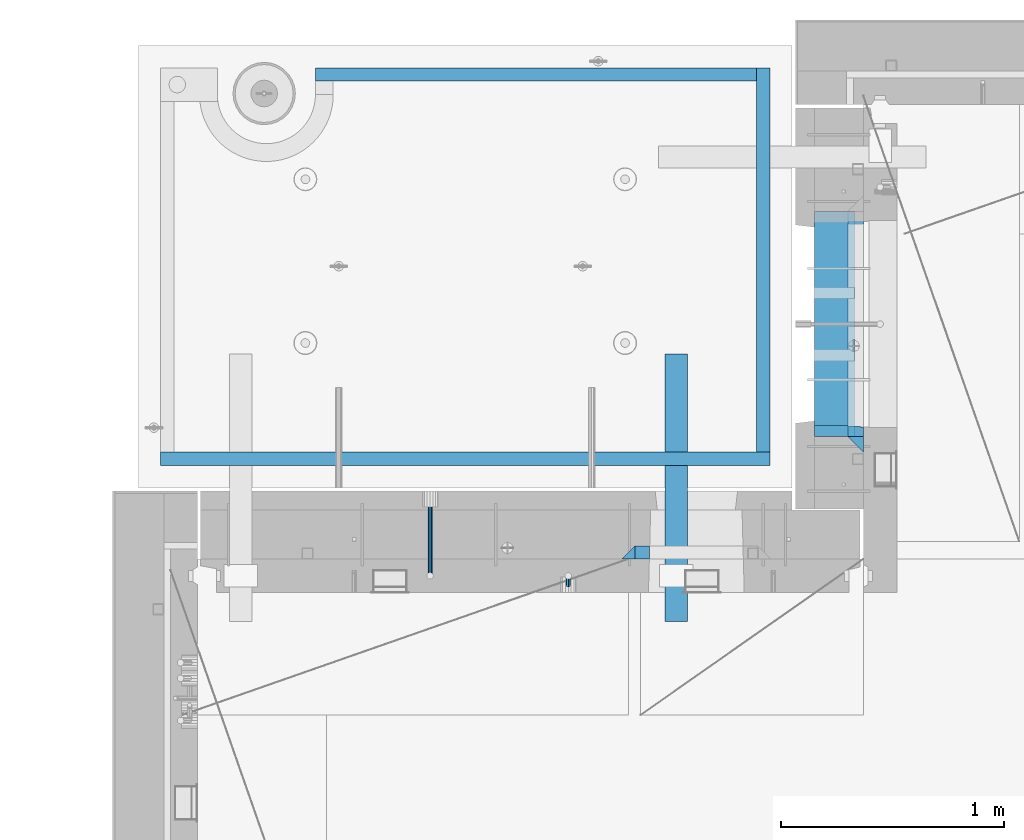
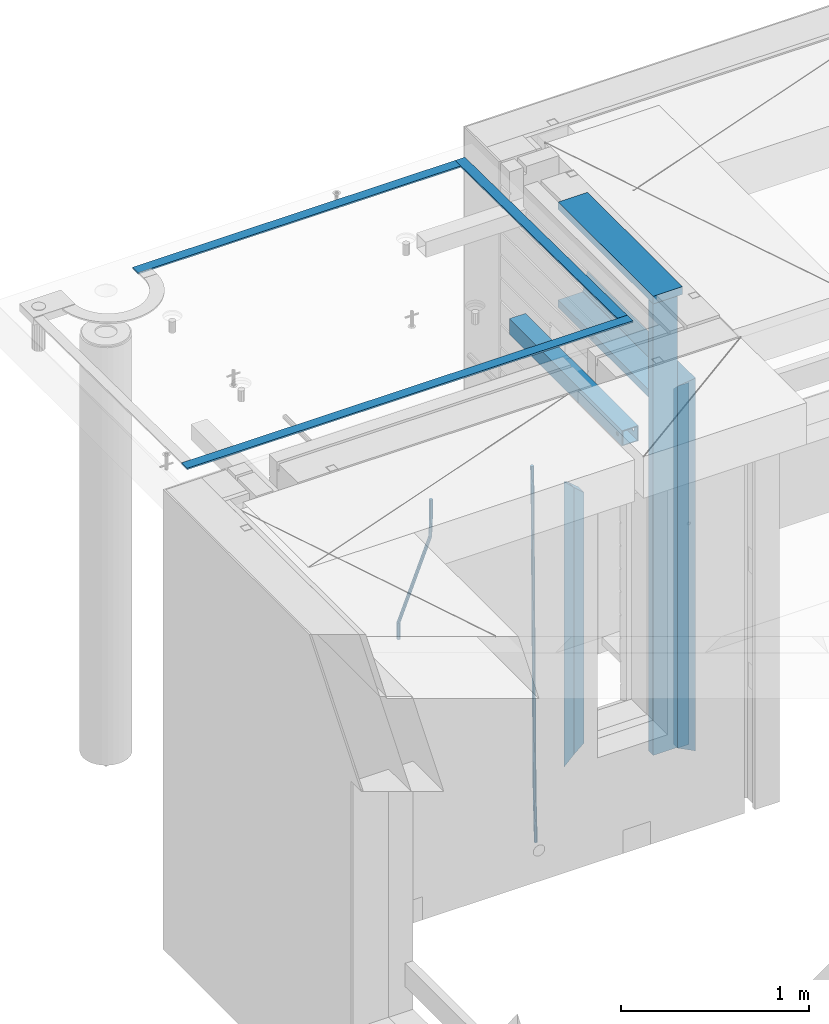
# One storey, part 116 of 349: 14 beams, 4 elements without a shape of their own.
"""IFC2X3 building model written with IfcOpenShell, lengths in millimetres."""

from ifc_helpers import new_model, si_unit, frame, origin_with_axes, place, context, subcontext, project, spatial, faceted_brep, material, type_object, element, aggregate, save


model = new_model("IFC2X3")

# Units and contexts
model_context = context("Model", 3, precision=1e-05, world=origin_with_axes())
body_context = subcontext(model_context, "Body", "Model", "MODEL_VIEW")
ifc_project = project(units=[si_unit("LENGTHUNIT", "METRE", prefix="MILLI"), si_unit("AREAUNIT", "SQUARE_METRE"), si_unit("VOLUMEUNIT", "CUBIC_METRE"), si_unit("MASSUNIT", "GRAM", prefix="KILO"), si_unit("TIMEUNIT", "SECOND"), si_unit("PLANEANGLEUNIT", "RADIAN"), si_unit("SOLIDANGLEUNIT", "STERADIAN"), si_unit("THERMODYNAMICTEMPERATUREUNIT", "DEGREE_CELSIUS"), si_unit("LUMINOUSINTENSITYUNIT", "LUMEN")], contexts=[model_context])

# Site, building, storey
site_placement = place(None, origin_with_axes())
site = spatial("IfcSite", under=ifc_project, at=site_placement, CompositionType="ELEMENT")
building_placement = place(site_placement, origin_with_axes())
building = spatial("IfcBuilding", under=site, at=building_placement, CompositionType="ELEMENT")
storey_placement = place(building_placement, origin_with_axes())
storey = spatial("IfcBuildingStorey", under=building, at=storey_placement, Name="4", CompositionType="ELEMENT", Elevation=0.0)

# Assembly, beams
assembly_1_placement = place(storey_placement, origin_with_axes())
assembly_1 = element("IfcElementAssembly", 1, at=assembly_1_placement, inside=storey, AssemblyPlace="NOTDEFINED", PredefinedType="REINFORCEMENT_UNIT")
ifc_material_1 = material(Name="CONCRETE/C25/30")
beam_type_1 = type_object("IfcBeamType", PredefinedType="NOTDEFINED")
beam_1_placement = place(assembly_1_placement, frame((10955.0, 22209.9998901814, 93140.0), z_axis=(0.0, 0.0, -1.0), x_axis=(0.0, -1.0, 0.0)))
beam_1 = element("IfcBeam", 2, at=beam_1_placement, type_object=beam_type_1, material=ifc_material_1, Name="SK", context=body_context, shape_type="Brep", body=[
    faceted_brep([(70.0000000000164, -35.0, 35.0), (70.0000000000164, 35.0, 35.0), (0.0, -35.0, -35.0), (1079.99961853027, -35.0, 35.0), (1079.99961853027, 35.0, 35.0), (1149.99961853027, -35.0, -35.0)], [[[0, 1, 2]], [[1, 0, 3, 4]], [[2, 1, 4, 5]], [[0, 2, 5, 3]], [[5, 4, 3]]]),
])
beam_2_placement = place(assembly_1_placement, frame((10955.0, 21095.0002716511, 93175.0), z_axis=(0.0, 1.0, 0.0), x_axis=(0.0, 0.0, -1.0)))
beam_2 = element("IfcBeam", 3, at=beam_2_placement, type_object=beam_type_1, material=ifc_material_1, Name="SK", context=body_context, shape_type="Brep", body=[
    faceted_brep([(2420.0, -35.0, 35.0), (2420.0, -35.0, -35.0), (2420.0, 35.0, 35.0), (70.0000000000164, -35.0, 35.0), (0.0, -35.0, -35.0), (70.0000000000164, 35.0, 35.0)], [[[0, 1, 2]], [[1, 0, 3, 4]], [[2, 1, 4, 5]], [[0, 2, 5, 3]], [[3, 5, 4]]]),
])
beam_type_2 = type_object("IfcBeamType", PredefinedType="NOTDEFINED")
beam_3_placement = place(assembly_1_placement, frame((10955.0, 21155.0002716511, 93105.0), z_axis=(0.0, 1.0, 0.0), x_axis=(0.0, 0.0, -1.0)))
beam_3 = element("IfcBeam", 4, at=beam_3_placement, type_object=beam_type_2, material=ifc_material_1, Name="SK", context=body_context, shape_type="Brep", body=[
    faceted_brep([(2350.0, -35.0, -25.0), (2350.0, 35.0, -25.0), (2350.0, 35.0, 20.6410256410309), (2350.0, -35.0, 18.8461538461561), (43.8461538461561, -35.0, 18.8461538461543), (0.0, -35.0, -25.0), (0.0, 35.0, -25.0), (45.6410256410309, 35.0, 20.6410256410254)], [[[0, 1, 2, 3]], [[0, 3, 4, 5]], [[1, 0, 5, 6]], [[2, 1, 6, 7]], [[3, 2, 7, 4]], [[7, 6, 5, 4]]]),
])
ifc_material_2 = material(Name="TIMBER")
beam_type_3 = type_object("IfcBeamType", Name="50X150", PredefinedType="NOTDEFINED")
beam_4_placement = place(assembly_1_placement, frame((10845.0, 22139.9998901814, 93080.0), z_axis=(0.0, 0.0, -1.0), x_axis=(0.0, -1.0, 0.0)))
beam_4 = element("IfcBeam", 5, at=beam_4_placement, type_object=beam_type_3, material=ifc_material_2, ObjectType="50X150", context=body_context, shape_type="Brep", body=[
    faceted_brep([(0.0, 75.0, -25.0), (1.81898940354586e-12, 75.0, 25.0), (1009.99961853027, 75.0, 25.0), (1009.99961853027, 75.0, -25.0), (1.81898940354586e-12, -75.0000000000009, 25.0), (1009.99961853027, -75.0, 25.0), (0.0, -75.0, -25.0), (1009.99961853027, -75.0, -25.0)], [[[0, 1, 2, 3]], [[1, 4, 5, 2]], [[4, 6, 7, 5]], [[6, 0, 3, 7]], [[5, 7, 3, 2]], [[6, 4, 1, 0]]]),
])
beam_5_placement = place(assembly_1_placement, frame((10845.0, 21155.0002716511, 93690.0), z_axis=(0.0, 1.0, 0.0), x_axis=(0.0, 0.0, -1.0)))
beam_5 = element("IfcBeam", 6, at=beam_5_placement, type_object=beam_type_3, material=ifc_material_2, ObjectType="50X150", context=body_context, shape_type="Brep", body=[
    faceted_brep([(0.0, 75.0, -25.0), (1.81898940354586e-12, 75.0, 25.0), (2930.0, 75.0, 25.0), (2930.0, 75.0, -25.0), (1.81898940354586e-12, -75.0000000000009, 25.0), (2930.0, -75.0, 25.0), (0.0, -75.0, -25.0), (2930.0, -75.0, -25.0)], [[[0, 1, 2, 3]], [[1, 4, 5, 2]], [[4, 6, 7, 5]], [[6, 0, 3, 7]], [[5, 7, 3, 2]], [[6, 4, 1, 0]]]),
])

assembly_2_placement = place(storey_placement, origin_with_axes())
assembly_2 = element("IfcElementAssembly", 7, at=assembly_2_placement, inside=storey, AssemblyPlace="NOTDEFINED", PredefinedType="REINFORCEMENT_UNIT")
ifc_material_3 = material()
beam_type_4 = type_object("IfcBeamType", Name="D20", PredefinedType="NOTDEFINED")
beam_6_placement = place(assembly_2_placement, frame((9665.0017200335, 20464.9951872276, 90990.0), z_axis=(-0.000205762999925498, 0.999642804629538, -0.0267249099901004), x_axis=(4.30000201928125e-08, 0.0267249099948059, 0.999642825806181)))
beam_6 = element("IfcBeam", 8, at=beam_6_placement, type_object=beam_type_4, material=ifc_material_3, Name="JM20", ObjectType="D20", context=body_context, shape_type="Brep", body=[
    faceted_brep([(0.0, -10.0, 0.0), (-4.19531716033816e-08, -7.07106781186667, -7.07106781187031), (60.4266690400545, -7.0710677960451, -7.07106780570757), (60.4266690441291, -9.99999998418934, 6.15546014159918e-09), (0.0, 0.0, -10.0), (60.426669036824, 1.58106558956206e-08, -9.99999999384454), (4.196772351861e-08, 7.07106781186303, -7.07106781186667), (60.4266690363438, 7.07106782768096, -7.07106780570757), (0.0, 10.0, 0.0), (60.4266690388904, 10.0000000158179, 6.15182216279209e-09), (4.196772351861e-08, 7.07106781185939, 7.07106781185939), (60.4266690429649, 7.07106782768096, 7.07106781802577), (0.0, 0.0, 10.0), (60.4266690461809, 1.58179318532348e-08, 10.0000000061555), (-4.19531716033816e-08, -7.07106781187031, 7.07106781185939), (60.4266690466611, -7.07106779605238, 7.07106781802213), (61.0378400410118, -7.07106779588503, -7.07106780564936), (60.991799419251, -9.99999998403655, 6.21366780251265e-09), (61.0569027789461, 1.5985278878361e-08, -9.99999999378269), (61.0378209396877, 7.07106782784831, -7.07106780564936), (60.9917724058905, 10.0000000159635, 6.21366780251265e-09), (60.9457317841297, 7.07106782781193, 7.0710678180767), (60.9266690461809, 1.59488990902901e-08, 10.0000000062028), (60.9457508854539, -7.07106779591413, 7.0710678180767), (61.6489592143771, -7.07106614513759, -7.06310863441468), (61.5568818710308, -9.9999984576425, 0.00735959856683621), (61.6870830769039, 1.71821739058942e-06, -9.99179257185824), (61.6489210170112, 7.07106947854481, -7.06310888312146), (61.556827851804, 10.0000015422847, 0.00735924683976918), (61.4647505084577, 7.07106922979438, 7.07782747982128), (61.4266266459163, 1.36643211590126e-06, 10.0065114172685), (61.464788705809, -7.07106639389531, 7.07782772852806), (176.543135720174, -7.07075579406956, -5.56673531796696), (176.451058376813, -9.99968810657447, 1.50373291501455), (176.581259582701, 0.000312069292704109, -8.49541925541052), (176.543097522794, 7.07137982961285, -5.56673556667374), (176.451004357587, 10.00031189336, 1.50373256329476), (176.35892701424, 7.07137958085514, 8.57420079627263), (176.320803151699, 0.000311717507429421, 11.5028847337162), (176.358965211621, -7.07075604281999, 8.57420104497578), (177.098753836006, -7.07075429323595, -5.55949898843028), (176.98362511232, -9.99968666800123, 1.510669025065), (177.146421932586, 0.000313595905026887, -8.48805862247536), (177.098706077581, 7.07138133041735, -5.55949936166144), (176.983557571715, 10.0003133318824, 1.51066849724157), (176.868428848029, 7.07138095712435, 8.58083651073321), (176.820760751449, 0.000313067976094317, 11.5093961447819), (176.868476606425, -7.07075466652896, 8.58083688396073), (177.654312950661, -7.07075204110879, -5.54863964998367), (177.516135294456, -9.99968450931192, 1.52107783331303), (177.711524267797, 0.000315886711177882, -8.47701274570863), (177.654255632195, 7.07138358250813, -5.54864021007961), (177.516054233929, 10.0003154905207, 1.5210770412159), (177.377876577739, 7.0713830223176, 8.59079452451624), (177.320665260588, 0.000315094497636892, 11.5191676202448), (177.377933896176, -7.07075260129932, 8.59079508461218), (299.436796249574, -7.07025836271714, -3.1681962331204), (299.298618593355, -9.99919083092027, 3.90152125031091), (299.494007566798, 0.000809565110102994, -6.09656932889993), (299.436738931283, 7.07187726089978, -3.16819679320906), (299.298537533061, 10.0008091689197, 3.90152045822106), (299.160359876842, 7.07187670072017, 10.9712379416487), (299.103148559603, 0.000808772889286047, 13.8996110374392), (299.160417195119, -7.07025892290039, 10.9712385017483), (299.98743051647, -7.07025613056248, -3.15743315966392), (299.971788958996, -9.99918809853989, 3.91467979818117), (299.993912075952, 0.000811591617093654, -6.08679785393178), (299.987423933868, 7.07187949325817, -3.1574327280432), (299.971753863239, 10.0008119014747, 3.91467990454839), (299.95611230444, 7.07187992653053, 10.9867922621015), (299.949630744944, 0.000812204350950196, 13.9161569563694), (299.956118887014, -7.07025569729012, 10.9867918304735), (300.538107039494, -7.07025785017686, -3.16575821840888), (300.644985195438, -9.99919020432935, 3.90450175465594), (300.493854948218, 0.000810030429420294, -6.09435592770024), (300.538151196495, 7.071877773491, -3.16575855385963), (300.645047642858, 10.0008097955724, 3.90450128024895), (300.751925798773, 7.07187744142357, 10.9747612533101), (300.796177890064, 0.000809560813650023, 13.9033589625978), (300.751881641787, -7.07025818224065, 10.9747615887682), (2293.36490490142, -7.07648090940347, -33.2930642912361), (2293.47178305736, -10.0054132635523, -26.2228043181785), (2293.32065281013, -0.00541302880083094, -36.2216620005347), (2293.36494905842, 7.06565471425711, -33.2930646266868), (2293.47184550477, 9.99458673634581, -26.2228047925819), (2293.57872366071, 7.06565438219332, -19.1525448195243), (2293.62297575199, -0.00541349841296324, -16.2239471102366), (2293.57867950371, -7.0764812414709, -19.1525444840736), (2294.0658245362, -7.07648309818615, -33.3036607065333), (2294.05312277409, -10.0054150789219, -26.2315929392535), (2294.10928714235, -0.00541549149056664, -36.2335844756526), (2294.15805078732, 7.06565223761572, -33.3050546393533), (2294.18355038921, 9.99458451388637, -26.2335642579346), (2294.17084862708, 7.06565253314329, -19.1614964906439), (2294.12738602093, -0.00541507354500936, -16.2315727215355), (2294.07862237596, -7.07648280265857, -19.1601025578348), (2294.76670261032, -7.08562269121467, -33.294332712383), (2294.63442802057, -10.0129954178956, -26.2238563411993), (2294.89787471293, -0.0156988342423574, -36.2230891548279), (2294.95110548967, 7.05531064255774, -33.2944998654275), (2294.89521307347, 9.98530428734011, -26.2240927312887), (2294.76293848372, 7.0579315606592, -19.1536163601049), (2294.63176638114, -0.0119922963167483, -16.2248599176673), (2294.57853560438, -7.08300177311321, -19.1534492070678), (2316.52657204497, -7.36937582653991, -33.0047303660212), (2316.39429745522, -10.2967485532172, -25.9342539948302), (2316.65774414754, -0.299451969567599, -35.9334868084661), (2316.7109749243, 6.7715575072325, -33.0048975190657), (2316.65508250811, 9.70155115201487, -25.9344903849269), (2316.52280791836, 6.7741784253376, -18.8640140137468), (2316.39163581574, -0.295745431634714, -15.9352575713092), (2316.33840503903, -7.36675490843481, -18.863846860706), (2317.16202064224, -7.37766220584308, -32.9962731735213), (2317.05438744847, -10.3053562613532, -25.9254688497131), (2317.23607125619, -0.306993473008333, -35.925789846493), (2317.23316144495, 6.76474808850253, -32.9979477328052), (2317.15499573652, 9.6950321815566, -25.9278370341635), (2317.04736254275, 6.7673381260538, -18.8570327103698), (2316.97331192881, -0.303330606784584, -15.9275160373909), (2316.97622174003, -7.37507216829545, -18.8553581510787), (2317.79752306276, -7.37578610372293, -32.9880110666527), (2317.71453320107, -10.3033876998124, -25.9168792378296), (2317.81444760226, -0.305295583297266, -35.918287695793), (2317.75539265381, 6.76628640723357, -32.9911928173897), (2317.65495180529, 9.69652304524061, -25.9213789128698), (2317.5719619436, 6.76892144914746, -18.8502470840467), (2317.55503740412, -0.301569071270933, -15.9199704549137), (2317.61409235255, -7.3731510618054, -18.847065333317), (2417.8183084176, -7.07752398473531, -31.6906369377139), (2417.73531855589, -10.0051255808248, -24.6195051088798), (2417.83523295709, -0.007033464313281, -34.6209135668432), (2417.77617800863, 7.06454852621755, -31.6938186884508), (2417.67573716014, 9.99478516423187, -24.6240047839383), (2417.59274729842, 7.06718356813872, -17.5528729551006), (2417.57582275895, -0.00330695228694822, -14.6225963259749), (2417.6348777074, -7.07488894281778, -17.5496912043673)], [[[0, 1, 2, 3]], [[1, 4, 5, 2]], [[4, 6, 7, 5]], [[6, 8, 9, 7]], [[8, 10, 11, 9]], [[10, 12, 13, 11]], [[12, 14, 15, 13]], [[14, 0, 3, 15]], [[14, 12, 10, 8, 6, 4, 1, 0]], [[3, 2, 16, 17]], [[2, 5, 18, 16]], [[5, 7, 19, 18]], [[7, 9, 20, 19]], [[9, 11, 21, 20]], [[11, 13, 22, 21]], [[13, 15, 23, 22]], [[15, 3, 17, 23]], [[17, 16, 24, 25]], [[16, 18, 26, 24]], [[18, 19, 27, 26]], [[19, 20, 28, 27]], [[20, 21, 29, 28]], [[21, 22, 30, 29]], [[22, 23, 31, 30]], [[23, 17, 25, 31]], [[25, 24, 32, 33]], [[24, 26, 34, 32]], [[26, 27, 35, 34]], [[27, 28, 36, 35]], [[28, 29, 37, 36]], [[29, 30, 38, 37]], [[30, 31, 39, 38]], [[31, 25, 33, 39]], [[33, 32, 40, 41]], [[32, 34, 42, 40]], [[34, 35, 43, 42]], [[35, 36, 44, 43]], [[36, 37, 45, 44]], [[37, 38, 46, 45]], [[38, 39, 47, 46]], [[39, 33, 41, 47]], [[41, 40, 48, 49]], [[40, 42, 50, 48]], [[42, 43, 51, 50]], [[43, 44, 52, 51]], [[44, 45, 53, 52]], [[45, 46, 54, 53]], [[46, 47, 55, 54]], [[47, 41, 49, 55]], [[49, 48, 56, 57]], [[48, 50, 58, 56]], [[50, 51, 59, 58]], [[51, 52, 60, 59]], [[52, 53, 61, 60]], [[53, 54, 62, 61]], [[54, 55, 63, 62]], [[55, 49, 57, 63]], [[57, 56, 64, 65]], [[56, 58, 66, 64]], [[58, 59, 67, 66]], [[59, 60, 68, 67]], [[60, 61, 69, 68]], [[61, 62, 70, 69]], [[62, 63, 71, 70]], [[63, 57, 65, 71]], [[65, 64, 72, 73]], [[64, 66, 74, 72]], [[66, 67, 75, 74]], [[67, 68, 76, 75]], [[68, 69, 77, 76]], [[69, 70, 78, 77]], [[70, 71, 79, 78]], [[71, 65, 73, 79]], [[73, 72, 80, 81]], [[72, 74, 82, 80]], [[74, 75, 83, 82]], [[75, 76, 84, 83]], [[76, 77, 85, 84]], [[77, 78, 86, 85]], [[78, 79, 87, 86]], [[79, 73, 81, 87]], [[81, 80, 88, 89]], [[80, 82, 90, 88]], [[82, 83, 91, 90]], [[83, 84, 92, 91]], [[84, 85, 93, 92]], [[85, 86, 94, 93]], [[86, 87, 95, 94]], [[87, 81, 89, 95]], [[89, 88, 96, 97]], [[88, 90, 98, 96]], [[90, 91, 99, 98]], [[91, 92, 100, 99]], [[92, 93, 101, 100]], [[93, 94, 102, 101]], [[94, 95, 103, 102]], [[95, 89, 97, 103]], [[97, 96, 104, 105]], [[96, 98, 106, 104]], [[98, 99, 107, 106]], [[99, 100, 108, 107]], [[100, 101, 109, 108]], [[101, 102, 110, 109]], [[102, 103, 111, 110]], [[103, 97, 105, 111]], [[105, 104, 112, 113]], [[104, 106, 114, 112]], [[106, 107, 115, 114]], [[107, 108, 116, 115]], [[108, 109, 117, 116]], [[109, 110, 118, 117]], [[110, 111, 119, 118]], [[111, 105, 113, 119]], [[113, 112, 120, 121]], [[112, 114, 122, 120]], [[114, 115, 123, 122]], [[115, 116, 124, 123]], [[116, 117, 125, 124]], [[117, 118, 126, 125]], [[118, 119, 127, 126]], [[119, 113, 121, 127]], [[121, 120, 128, 129]], [[120, 122, 130, 128]], [[122, 123, 131, 130]], [[123, 124, 132, 131]], [[124, 125, 133, 132]], [[125, 126, 134, 133]], [[126, 127, 135, 134]], [[127, 121, 129, 135]], [[130, 131, 132, 133, 134, 135, 129, 128]]]),
])
beam_7_placement = place(assembly_2_placement, frame((9044.99633337453, 20504.9951872346, 93407.5), z_axis=(0.000415599999849905, 0.999999913638203, 4.76000000899737e-07), x_axis=(0.0, 0.0, -1.0)))
beam_7 = element("IfcBeam", 9, at=beam_7_placement, type_object=beam_type_4, material=ifc_material_3, Name="JM20", ObjectType="D20", context=body_context, shape_type="Brep", body=[
    faceted_brep([(-0.00060564729210455, -9.99999998165731, 0.0), (-0.000428079845733009, -7.07106779890455, -7.07106781186667), (119.575515501536, -7.07830994756296, -7.07106481604933), (119.575337932896, -10.0072421307195, -3.43332612828817e-06), (0.0, 0.0, -10.0), (119.575943836026, -0.00724214867295814, -9.99999700418266), (0.00042843479604926, 7.07106779888636, -7.07106781186303), (119.57637202373, 7.06382565022977, -7.07106481604933), (0.00060564729210455, 9.99999998166459, 3.63797880709171e-12), (119.576549238118, 9.99275783300072, 2.99581552098971e-06), (0.000428079845733009, 7.07106779890819, 7.07106781186667), (119.576371669405, 7.06382565024978, 7.07107080768037), (0.0, 0.0, 10.0), (119.57594333493, -0.00724214864203532, 10.0000029958155), (-0.000428434810601175, -7.07106779888272, 7.07106781186667), (119.575515147211, -7.07830994754295, 7.07107080768037), (123.00654325854, -7.07836650239551, -6.96786008391246), (122.581588830741, -10.007295666459, 0.0904344953341933), (123.182419066041, -0.00729994480025198, -9.89151006310021), (123.006190977103, 7.06376911688858, -6.96788735351402), (122.581091016109, 9.99270432680532, 0.0903895128230943), (122.156136974867, 7.06377516229986, 7.14867767459873), (121.980261167351, -0.00729139528993983, 10.0723276537792), (122.156489256289, -7.07836045697513, 7.14870494419847), (237.077376207715, -7.07551629289992, -0.0988779924864502), (236.652422053201, -10.0044409119728, 6.95941204931296), (237.253252288647, -0.0044516184279928, -3.02253250974718), (237.077024472936, 7.06661932641327, -0.0989143382521434), (236.651924624995, 9.99555908263574, 6.95936064834314), (236.226970470365, 7.06663446442326, 14.0176506898479), (236.051094389448, -0.0044302100486675, 16.9413052071086), (236.227322205144, -7.07550115488812, 14.0176870356117), (256.715938387759, -7.07353516174771, 4.66794781703175), (253.858321224223, -10.0027051854922, 11.1357628166734), (257.898622435067, -0.00236892073007766, 1.98867362452802), (256.713573090979, 7.0686002544353, 4.66742272414376), (253.85497618909, 9.99729452004976, 11.1350202234971), (250.997359025234, 7.06812449537756, 17.6028352234607), (249.814674977912, -0.00304174564189452, 20.2821094159572), (250.999724322028, -7.07401092080545, 17.6033603163596), (1009.84102825288, -6.93521658215468, 337.477148757798), (1006.98341108896, -9.86438660663771, 343.944963757851), (1011.02371230032, 0.135949658781101, 334.7978745651), (1009.83866295629, 7.20691883402651, 337.476623664521), (1006.98006605446, 10.1356130998429, 343.944221163818), (1004.12244889054, 7.2064430753635, 350.412036163872), (1002.9397648431, 0.135276834424076, 353.091310356571), (1004.12481418712, -6.93569234081951, 350.412561257146), (1010.86335274603, -6.9350288225487, 337.928918327354), (1009.37086865908, -9.86394812736762, 344.999991477531), (1011.48104818776, 0.136033652863262, 334.999973251377), (1010.86211737194, 7.20710680115553, 337.928892551665), (1009.36912157628, 10.1360518725905, 344.9999550252), (1007.87663748935, 7.2071325677698, 352.071028175378), (1007.2589420476, 0.13607009235966, 354.999973251352), (1007.87787286344, -6.93500305593261, 352.071053951067), (1011.98104820926, -6.93502881915083, 337.92891832735), (1011.98104821818, -9.86394811943501, 344.999991477524), (1011.98104818776, 0.136033654382118, 334.999973251375), (1011.98104816627, 7.20710680455704, 337.928892551661), (1011.98104815738, 10.1360518805304, 344.999955025194), (1011.98104816629, 7.20713258024625, 352.071028175369), (1011.98104818778, 0.136070106711486, 354.999973251342), (1011.98104820927, -6.9350030434598, 352.071053951058), (1117.50000002154, -6.93502849844299, 337.928918327156), (1117.50000003044, -9.86394779872717, 344.999991477331), (1117.50000000004, 0.136033975091777, 334.999973251181), (1117.49999997855, 7.20710712526488, 337.928892551467), (1117.49999996964, 10.1360522012383, 344.999955025), (1117.49999997857, 7.20713290095409, 352.071028175174), (1117.50000000006, 0.136070427419327, 354.999973251148), (1117.50000002155, -6.93500272275196, 352.071053950864)], [[[0, 1, 2, 3]], [[1, 4, 5, 2]], [[4, 6, 7, 5]], [[6, 8, 9, 7]], [[8, 10, 11, 9]], [[10, 12, 13, 11]], [[12, 14, 15, 13]], [[14, 0, 3, 15]], [[14, 12, 10, 8, 6, 4, 1, 0]], [[3, 2, 16, 17]], [[2, 5, 18, 16]], [[5, 7, 19, 18]], [[7, 9, 20, 19]], [[9, 11, 21, 20]], [[11, 13, 22, 21]], [[13, 15, 23, 22]], [[15, 3, 17, 23]], [[17, 16, 24, 25]], [[16, 18, 26, 24]], [[18, 19, 27, 26]], [[19, 20, 28, 27]], [[20, 21, 29, 28]], [[21, 22, 30, 29]], [[22, 23, 31, 30]], [[23, 17, 25, 31]], [[25, 24, 32, 33]], [[24, 26, 34, 32]], [[26, 27, 35, 34]], [[27, 28, 36, 35]], [[28, 29, 37, 36]], [[29, 30, 38, 37]], [[30, 31, 39, 38]], [[31, 25, 33, 39]], [[33, 32, 40, 41]], [[32, 34, 42, 40]], [[34, 35, 43, 42]], [[35, 36, 44, 43]], [[36, 37, 45, 44]], [[37, 38, 46, 45]], [[38, 39, 47, 46]], [[39, 33, 41, 47]], [[41, 40, 48, 49]], [[40, 42, 50, 48]], [[42, 43, 51, 50]], [[43, 44, 52, 51]], [[44, 45, 53, 52]], [[45, 46, 54, 53]], [[46, 47, 55, 54]], [[47, 41, 49, 55]], [[49, 48, 56, 57]], [[48, 50, 58, 56]], [[50, 51, 59, 58]], [[51, 52, 60, 59]], [[52, 53, 61, 60]], [[53, 54, 62, 61]], [[54, 55, 63, 62]], [[55, 49, 57, 63]], [[57, 56, 64, 65]], [[56, 58, 66, 64]], [[58, 59, 67, 66]], [[59, 60, 68, 67]], [[60, 61, 69, 68]], [[61, 62, 70, 69]], [[62, 63, 71, 70]], [[63, 57, 65, 71]], [[66, 67, 68, 69, 70, 71, 65, 64]]]),
])

# Assemblies, beams
assembly_3_placement = place(storey_placement, origin_with_axes())
assembly_3 = element("IfcElementAssembly", 10, at=assembly_3_placement, inside=storey, AssemblyPlace="NOTDEFINED", PredefinedType="REINFORCEMENT_UNIT")
assembly_4_placement = place(assembly_3_placement, origin_with_axes())
assembly_4 = element("IfcElementAssembly", 11, at=assembly_4_placement, AssemblyPlace="NOTDEFINED", PredefinedType="NOTDEFINED")
ifc_material_4 = material(Name="Undefined/350")
beam_type_5 = type_object("IfcBeamType", Name="100X100X5", PredefinedType="NOTDEFINED")
beam_8_placement = place(assembly_4_placement, frame((10150.0001432011, 21500.0034426031, 93555.0), z_axis=(0.0, 0.0, 1.0), x_axis=(-2.2242999997242e-05, -0.999999999752625, 0.0)))
beam_8 = element("IfcBeam", 12, at=beam_8_placement, type_object=beam_type_5, material=ifc_material_4, ObjectType="100X100X5", context=body_context, shape_type="Brep", body=[
    faceted_brep([(1143.75108023171, 44.9999999999982, -10.8253175473074), (1143.75107855316, 50.0255964196231, -10.8253175473074), (1139.17576100585, 50.0255948914664, -6.25), (1139.1757626844, 44.9999999999982, -6.25), (1150.00108023171, 44.9999999999982, -12.5), (1150.00107855316, 50.0255985071226, -12.5), (1156.2510802317, 44.9999999999982, -10.8253175473074), (1156.25107855315, 50.0256005946221, -10.8253175473074), (1160.82639777901, 44.9999999999982, -6.25), (1160.82639610046, 50.0256021227788, -6.25), (1162.50108023171, 44.9999999999982, 0.0), (1162.50107855316, 50.0256026821226, 0.0), (1160.82639777901, 44.9999999999982, 6.25), (1160.82639610046, 50.0256021227788, 6.25), (1156.2510802317, 44.9999999999982, 10.8253175473074), (1156.25107855315, 50.0256005946221, 10.8253175473074), (1150.00108023171, 44.9999999999982, 12.5), (1150.00107855316, 50.0255985071226, 12.5), (1143.75108023171, 44.9999999999982, 10.8253175473074), (1143.75107855316, 50.0255964196231, 10.8253175473074), (1139.1757626844, 44.9999999999982, 6.25), (1139.17576100585, 50.0255948914664, 6.25), (1137.5010802317, 44.9999999999982, 0.0), (1137.50107855316, 50.0255943321226, 0.0), (1143.75111195316, -49.9744035792783, -10.8253175473074), (1143.75111029171, -44.9999999999991, -10.8253175473074), (1139.1757927444, -44.9999999999991, -6.25), (1139.17579440585, -49.9744051074349, -6.25), (1150.00111195316, -49.9744014917787, -12.5), (1150.00111029171, -44.9999999999991, -12.5), (1156.25111195316, -49.9743994042774, -10.8253175473074), (1156.25111029171, -44.9999999999991, -10.8253175473074), (1160.82642950046, -49.9743978761207, -6.25), (1160.82642783901, -44.9999999999991, -6.25), (1162.50111195316, -49.9743973167779, 0.0), (1162.50111029171, -44.9999999999991, 0.0), (1160.82642950046, -49.9743978761207, 6.25), (1160.82642783901, -44.9999999999991, 6.25), (1156.25111195316, -49.9743994042774, 10.8253175473074), (1156.25111029171, -44.9999999999991, 10.8253175473074), (1150.00111195316, -49.9744014917787, 12.5), (1150.00111029171, -44.9999999999991, 12.5), (1143.75111195316, -49.9744035792783, 10.8253175473074), (1143.75111029171, -44.9999999999991, 10.8253175473074), (1139.17579440585, -49.9744051074349, 6.25), (1139.1757927444, -44.9999999999991, 6.25), (1137.50111195316, -49.9744056667778, 0.0), (1137.50111029171, -44.9999999999991, 0.0), (1.81898940354586e-12, -50.0000000000009, -50.0), (1.81898940354586e-12, 49.9999999999991, -50.0), (1200.00449189278, 49.9999999999982, -50.0), (1200.00449189278, -50.0000000000009, -50.0), (1.81898940354586e-12, 49.9999999999991, 50.0), (1.81898940354586e-12, -50.0000000000009, 50.0), (1200.00449189278, -50.0000000000009, 50.0), (1200.00449189278, 49.9999999999982, 50.0), (0.0, 44.9999999999991, 45.0), (1.81898940354586e-12, -45.0000000000009, 45.0), (1.81898940354586e-12, -45.0000000000009, -45.0), (0.0, 44.9999999999991, -45.0), (1200.00449189278, 44.9999999999982, -45.0), (1200.00449189278, 44.9999999999982, 45.0), (1200.00449189278, -45.0000000000009, 45.0), (1200.00449189278, -45.0000000000009, -45.0)], [[[0, 1, 2, 3]], [[4, 5, 1, 0]], [[6, 7, 5, 4]], [[8, 9, 7, 6]], [[10, 11, 9, 8]], [[12, 13, 11, 10]], [[14, 15, 13, 12]], [[16, 17, 15, 14]], [[18, 19, 17, 16]], [[20, 21, 19, 18]], [[22, 23, 21, 20]], [[3, 2, 23, 22]], [[24, 25, 26, 27]], [[28, 29, 25, 24]], [[30, 31, 29, 28]], [[32, 33, 31, 30]], [[34, 35, 33, 32]], [[36, 37, 35, 34]], [[38, 39, 37, 36]], [[40, 41, 39, 38]], [[42, 43, 41, 40]], [[44, 45, 43, 42]], [[46, 47, 45, 44]], [[27, 26, 47, 46]], [[48, 49, 50, 51]], [[52, 53, 54, 55]], [[49, 52, 55, 50], [15, 17, 19, 21, 23, 2, 1, 5, 7, 9, 11, 13]], [[48, 53, 52, 49], [56, 57, 58, 59]], [[56, 59, 60, 61], [6, 4, 0, 3, 22, 20, 18, 16, 14, 12, 10, 8]], [[57, 56, 61, 62]], [[58, 57, 62, 63], [39, 41, 43, 45, 47, 26, 25, 29, 31, 33, 35, 37]], [[59, 58, 63, 60]], [[54, 51, 50, 55], [62, 61, 60, 63]], [[53, 48, 51, 54], [30, 28, 24, 27, 46, 44, 42, 40, 38, 36, 34, 32]]]),
])
aggregate(assembly_4, [beam_8])
ifc_material_5 = material(Name="CONCRETE/Concrete_Undefined")
beam_type_6 = type_object("IfcBeamType", PredefinedType="NOTDEFINED")
beam_9_placement = place(assembly_3_placement, frame((8529.99466999203, 22755.2837502302, 93704.830444231), z_axis=(-8.94119999996021e-05, 2.00000067707701e-09, 0.999999996002747), x_axis=(0.999999995749149, -2.25209999937896e-05, 8.94119999812374e-05)))
beam_9 = element("IfcBeam", 13, at=beam_9_placement, type_object=beam_type_6, material=ifc_material_5, context=body_context, shape_type="Brep", body=[
    faceted_brep([(2.5465851649642e-11, 29.9999999999982, -4.99999999998545), (-2.91038304567337e-11, 29.9999999999982, 5.0), (1980.00575712919, 30.0, 5.0), (1980.00575712919, 30.0, -5.0), (-2.5465851649642e-11, -30.0000000000018, 5.0), (1980.00575712919, -30.0, 5.0), (2.72848410531878e-11, -30.0000000000018, -4.99999999998545), (1980.00575712919, -30.0, -5.00000000001455)], [[[0, 1, 2, 3]], [[1, 4, 5, 2]], [[4, 6, 7, 5]], [[6, 0, 3, 7]], [[5, 7, 3, 2]], [[6, 4, 1, 0]]]),
])
beam_10_placement = place(assembly_3_placement, frame((10540.0586106742, 21059.9845873458, 93725.6637899649), z_axis=(-4.06999999693443e-07, 0.0121707750045615, 0.999925933374879), x_axis=(-3.34759999933477e-05, 0.999925932814682, -0.0121707749977451)))
beam_10 = element("IfcBeam", 14, at=beam_10_placement, type_object=beam_type_6, material=ifc_material_5, context=body_context, shape_type="Brep", body=[
    faceted_brep([(2.5465851649642e-11, 29.9999999999982, -4.99999999998545), (-2.91038304567337e-11, 29.9999999999982, 5.0), (1725.44357525616, 30.0000000000036, 5.00000000001455), (1725.4435752563, 30.0, -4.9999999999709), (-2.5465851649642e-11, -30.0000000000018, 5.0), (1725.44357525616, -29.9999999999964, 5.0000000000291), (2.72848410531878e-11, -30.0000000000018, -4.99999999998545), (1725.4435752563, -30.0, -4.99999999998545)], [[[0, 1, 2, 3]], [[1, 4, 5, 2]], [[4, 6, 7, 5]], [[6, 0, 3, 7]], [[5, 7, 3, 2]], [[6, 4, 1, 0]]]),
])
beam_11_placement = place(assembly_3_placement, frame((7834.99819277187, 21029.998155674, 93725.2788443216), z_axis=(-0.000140627000015522, 4.00000135459113e-09, 0.999999990112023), x_axis=(0.999999989763253, -2.64109999939869e-05, 0.000140626999967189)))
beam_11 = element("IfcBeam", 15, at=beam_11_placement, type_object=beam_type_6, material=ifc_material_5, context=body_context, shape_type="Brep", body=[
    faceted_brep([(2.5465851649642e-11, 29.9999999999982, -4.99999999998545), (-2.91038304567337e-11, 29.9999999999982, 5.0), (2735.00002544224, 30.0, 5.0), (2735.00002544224, 30.0, -5.0), (-2.5465851649642e-11, -30.0000000000018, 5.0), (2735.00002544224, -29.9999999999964, 5.0), (2.72848410531878e-11, -30.0000000000018, -4.99999999998545), (2735.00002544224, -29.9999999999964, -5.0)], [[[0, 1, 2, 3]], [[1, 4, 5, 2]], [[4, 6, 7, 5]], [[6, 0, 3, 7]], [[5, 7, 3, 2]], [[6, 4, 1, 0]]]),
])
aggregate(assembly_3, [assembly_4, beam_9, beam_10, beam_11])

# Beam
beam_type_7 = type_object("IfcBeamType", PredefinedType="NOTDEFINED")
beam_12_placement = place(assembly_2_placement, frame((9934.99871015549, 20609.9951872276, 93175.0), z_axis=(1.0, 0.0, 0.0), x_axis=(0.0, 0.0, -1.0)))
beam_12 = element("IfcBeam", 16, at=beam_12_placement, type_object=beam_type_7, material=ifc_material_1, Name="SK", context=body_context, shape_type="Brep", body=[
    faceted_brep([(60.0000000000073, 30.0, 30.0), (0.0, -30.0, -30.0), (60.0000000000073, -30.0, 30.0), (1795.00000000001, 30.0, 30.0), (1855.0, -30.0, -30.0), (1795.00000000001, -30.0, 30.0)], [[[0, 1, 2]], [[3, 4, 1, 0]], [[4, 5, 2, 1]], [[5, 3, 0, 2]], [[5, 4, 3]]]),
])

beam_type_8 = type_object("IfcBeamType", PredefinedType="NOTDEFINED")
beam_13_placement = place(assembly_2_placement, frame((9999.99871015549, 20609.9951872276, 93115.0), z_axis=(1.0, 0.0, 0.0), x_axis=(0.0, 0.0, -1.0)))
beam_13 = element("IfcBeam", 17, at=beam_13_placement, type_object=beam_type_8, material=ifc_material_1, Name="SK", context=body_context, shape_type="Brep", body=[
    faceted_brep([(0.0, -30.0, -35.0), (54.9034748914273, -30.0, 29.0540540540533), (56.2934362811066, 30.0, 30.6756756756768), (0.0, 30.0, -35.0), (1678.70656371891, 30.0, 30.6756756756768), (1735.0, 30.0, -35.0), (1735.0, -30.0, -35.0), (1680.09652510857, -30.0, 29.0540540540533)], [[[0, 1, 2, 3]], [[3, 2, 4, 5]], [[5, 6, 0, 3]], [[1, 0, 6, 7]], [[2, 1, 7, 4]], [[6, 5, 4, 7]]]),
])

aggregate(assembly_2, [beam_6, beam_7, beam_12, beam_13])

beam_type_9 = type_object("IfcBeamType", PredefinedType="NOTDEFINED")
beam_14_placement = place(assembly_1_placement, frame((10860.0, 21129.9999618525, 93715.0), z_axis=(0.0, 0.0, 1.0), x_axis=(0.0, 1.0, 0.0)))
beam_14 = element("IfcBeam", 18, at=beam_14_placement, type_object=beam_type_9, material=ifc_material_2, context=body_context, shape_type="Brep", body=[
    faceted_brep([(0.0, 90.0, -25.0), (0.0, 90.0, 25.0), (1009.99983857082, 90.0, 25.0), (1009.99983857082, 90.0, -25.0), (0.0, -90.0, 25.0), (1009.99983857082, -90.0, 25.0), (0.0, -90.0, -25.0), (1009.99983857082, -90.0, -25.0)], [[[0, 1, 2, 3]], [[1, 4, 5, 2]], [[4, 6, 7, 5]], [[6, 0, 3, 7]], [[5, 7, 3, 2]], [[6, 4, 1, 0]]]),
])

aggregate(assembly_1, [beam_1, beam_2, beam_3, beam_4, beam_5, beam_14])

save(model, "model.ifc")
